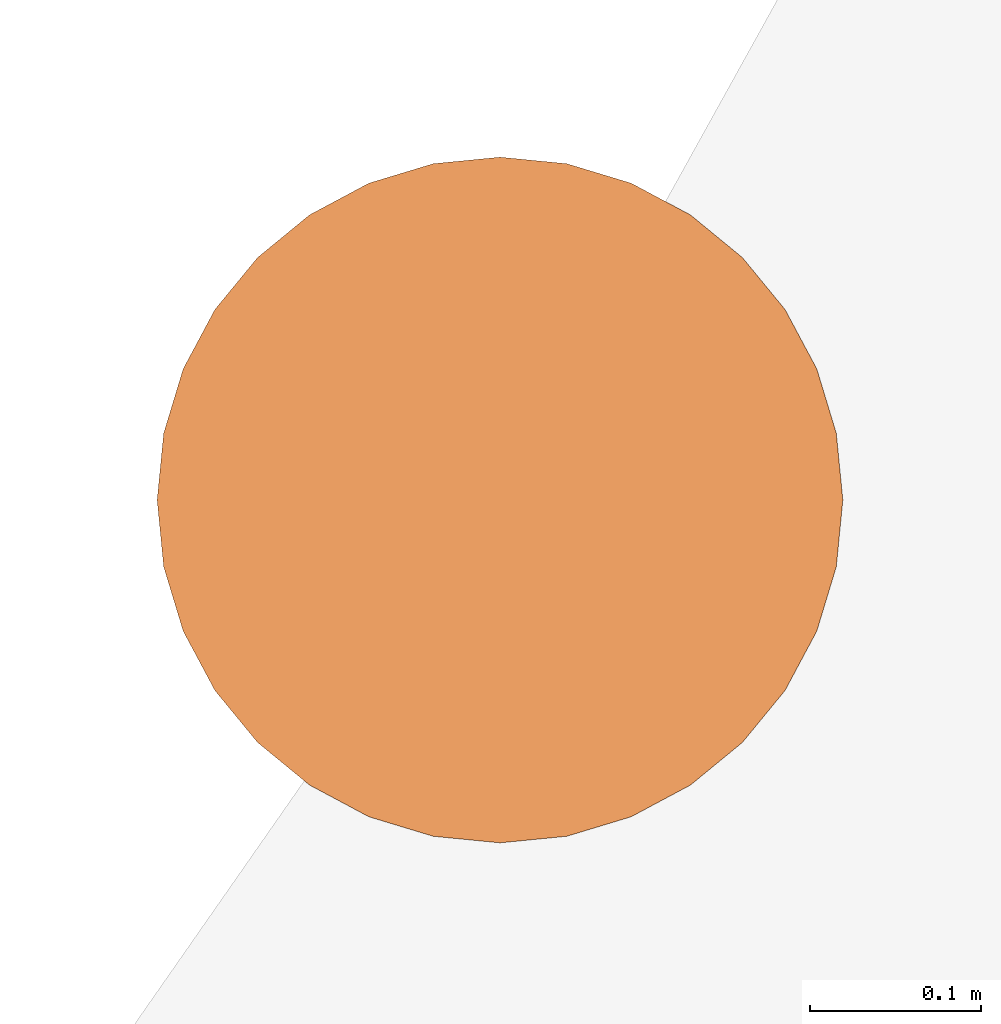
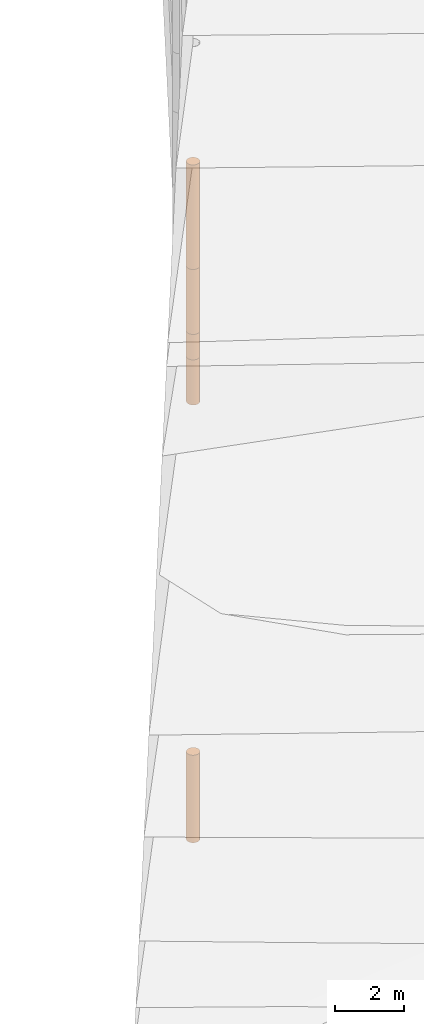
# One storey, part 9 of 24: 5 geographic elements.
"""IFC4 building model written with IfcOpenShell, lengths in metres."""

from ifc_helpers import new_model, entity, si_unit, converted_unit, frame, origin_with_axes, origin_2d_with_axis, place, context, subcontext, project, spatial, polygons, element, save


model = new_model("IFC4")

# Units and contexts
model_context = context("Model", 3, precision=1e-05, world=origin_with_axes())
plan_context = context("Plan", 2, precision=1e-05, world=origin_2d_with_axis())
body_context = subcontext(model_context, "Body", "Model", "MODEL_VIEW")
ifc_project = project(units=[converted_unit("PLANEANGLEUNIT", "degree", entity("IfcReal", 0.0174532925199433), si_unit("PLANEANGLEUNIT", "RADIAN"), dimensions=[0, 0, 0, 0, 0, 0, 0]), si_unit("AREAUNIT", "SQUARE_METRE"), si_unit("VOLUMEUNIT", "CUBIC_METRE"), si_unit("LENGTHUNIT", "METRE")], contexts=[model_context, plan_context])

# Site, building, storey
site_placement = place(None, origin_with_axes())
site = spatial("IfcSite", under=ifc_project, at=site_placement)
building_placement = place(site_placement, origin_with_axes())
building = spatial("IfcBuilding", under=site, at=building_placement, Name="Building")
storey_placement = place(building_placement, origin_with_axes())
storey = spatial("IfcBuildingStorey", under=building, at=storey_placement, Name="Storey")

# Geographic elements
geographic_element_1_placement = place(storey_placement, frame((-10.8999996185303, 35.5, 5.54999971389771), z_axis=(0.0, 0.0, 1.0), x_axis=(1.0, 0.0, 0.0)))
element("IfcGeographicElement", 1, at=geographic_element_1_placement, inside=storey, PredefinedType="NOTDEFINED", context=body_context, shape_type="Tessellation", body=[
    polygons([(0.0, 0.0, -0.449999958276749), (0.0390180610120296, 0.196157038211823, -0.449999958276749), (0.0, 0.199999988079071, -0.449999958276749), (0.0, 0.0, 0.449999958276749), (0.0, 0.199999988079071, 0.449999958276749), (0.0390180610120296, 0.196157038211823, 0.449999958276749), (0.0765366926789284, 0.18477588891983, -0.449999958276749), (0.0765366926789284, 0.18477588891983, 0.449999958276749), (0.111114047467709, 0.166293919086456, -0.449999958276749), (0.111114047467709, 0.166293919086456, 0.449999958276749), (0.141421362757683, 0.141421362757683, -0.449999958276749), (0.141421362757683, 0.141421362757683, 0.449999958276749), (0.166293919086456, 0.111114047467709, -0.449999958276749), (0.166293919086456, 0.111114047467709, 0.449999958276749), (0.18477588891983, 0.0765366926789284, -0.449999958276749), (0.18477588891983, 0.0765366926789284, 0.449999958276749), (0.196157038211823, 0.0390180610120296, -0.449999958276749), (0.196157038211823, 0.0390180610120296, 0.449999958276749), (0.199999988079071, 0.0, -0.449999958276749), (0.199999988079071, 0.0, 0.449999958276749), (0.196157038211823, -0.0390180610120296, -0.449999958276749), (0.196157038211823, -0.0390180610120296, 0.449999958276749), (0.18477588891983, -0.0765366926789284, -0.449999958276749), (0.18477588891983, -0.0765366926789284, 0.449999958276749), (0.166293919086456, -0.111114047467709, -0.449999958276749), (0.166293919086456, -0.111114047467709, 0.449999958276749), (0.141421362757683, -0.141421362757683, -0.449999958276749), (0.141421362757683, -0.141421362757683, 0.449999958276749), (0.111114047467709, -0.166293919086456, -0.449999958276749), (0.111114047467709, -0.166293919086456, 0.449999958276749), (0.0765366926789284, -0.18477588891983, -0.449999958276749), (0.0765366926789284, -0.18477588891983, 0.449999958276749), (0.0390180610120296, -0.196157038211823, -0.449999958276749), (0.0390180610120296, -0.196157038211823, 0.449999958276749), (0.0, -0.199999988079071, -0.449999958276749), (0.0, -0.199999988079071, 0.449999958276749), (-0.0390180610120296, -0.196157038211823, -0.449999958276749), (-0.0390180610120296, -0.196157038211823, 0.449999958276749), (-0.0765366926789284, -0.18477588891983, -0.449999958276749), (-0.0765366926789284, -0.18477588891983, 0.449999958276749), (-0.111114047467709, -0.166293919086456, -0.449999958276749), (-0.111114047467709, -0.166293919086456, 0.449999958276749), (-0.141421362757683, -0.141421362757683, -0.449999958276749), (-0.141421362757683, -0.141421362757683, 0.449999958276749), (-0.166293919086456, -0.111114047467709, -0.449999958276749), (-0.166293919086456, -0.111114047467709, 0.449999958276749), (-0.18477588891983, -0.0765366926789284, -0.449999958276749), (-0.18477588891983, -0.0765366926789284, 0.449999958276749), (-0.196157038211823, -0.0390180610120296, -0.449999958276749), (-0.196157038211823, -0.0390180610120296, 0.449999958276749), (-0.199999988079071, 0.0, -0.449999958276749), (-0.199999988079071, 0.0, 0.449999958276749), (-0.196157038211823, 0.0390180610120296, -0.449999958276749), (-0.196157038211823, 0.0390180610120296, 0.449999958276749), (-0.18477588891983, 0.0765366926789284, -0.449999958276749), (-0.18477588891983, 0.0765366926789284, 0.449999958276749), (-0.166293919086456, 0.111114047467709, -0.449999958276749), (-0.166293919086456, 0.111114047467709, 0.449999958276749), (-0.141421362757683, 0.141421362757683, -0.449999958276749), (-0.141421362757683, 0.141421362757683, 0.449999958276749), (-0.111114047467709, 0.166293919086456, -0.449999958276749), (-0.111114047467709, 0.166293919086456, 0.449999958276749), (-0.0765366926789284, 0.18477588891983, -0.449999958276749), (-0.0765366926789284, 0.18477588891983, 0.449999958276749), (-0.0390180610120296, 0.196157038211823, -0.449999958276749), (-0.0390180610120296, 0.196157038211823, 0.449999958276749)], [[[3, 2, 1]], [[6, 5, 4]], [[32, 34, 33, 31]], [[2, 7, 1]], [[8, 6, 4]], [[64, 66, 65, 63]], [[7, 9, 1]], [[10, 8, 4]], [[9, 11, 1]], [[12, 10, 4]], [[40, 42, 41, 39]], [[1, 11, 13]], [[12, 4, 14]], [[10, 12, 11, 9]], [[1, 13, 15]], [[4, 16, 14]], [[12, 14, 13, 11]], [[1, 15, 17]], [[16, 4, 18]], [[18, 20, 19, 17]], [[1, 17, 19]], [[4, 20, 18]], [[20, 22, 21, 19]], [[1, 19, 21]], [[4, 22, 20]], [[22, 24, 23, 21]], [[1, 21, 23]], [[22, 4, 24]], [[54, 56, 55, 53]], [[1, 23, 25]], [[4, 26, 24]], [[56, 58, 57, 55]], [[1, 25, 27]], [[4, 28, 26]], [[24, 26, 25, 23]], [[1, 27, 29]], [[28, 4, 30]], [[26, 28, 27, 25]], [[1, 29, 31]], [[4, 32, 30]], [[46, 48, 47, 45]], [[1, 31, 33]], [[4, 34, 32]], [[36, 38, 37, 35]], [[1, 33, 35]], [[4, 36, 34]], [[42, 44, 43, 41]], [[1, 35, 37]], [[4, 38, 36]], [[38, 40, 39, 37]], [[1, 37, 39]], [[4, 40, 38]], [[34, 36, 35, 33]], [[1, 39, 41]], [[4, 42, 40]], [[8, 10, 9, 7]], [[43, 1, 41]], [[4, 44, 42]], [[44, 46, 45, 43]], [[43, 45, 1]], [[4, 46, 44]], [[30, 32, 31, 29]], [[45, 47, 1]], [[48, 46, 4]], [[28, 30, 29, 27]], [[49, 1, 47]], [[4, 50, 48]], [[5, 6, 2, 3]], [[49, 51, 1]], [[52, 50, 4]], [[48, 50, 49, 47]], [[51, 53, 1]], [[54, 52, 4]], [[50, 52, 51, 49]], [[55, 1, 53]], [[4, 56, 54]], [[52, 54, 53, 51]], [[55, 57, 1]], [[58, 56, 4]], [[58, 60, 59, 57]], [[59, 1, 57]], [[60, 58, 4]], [[60, 62, 61, 59]], [[59, 61, 1]], [[62, 60, 4]], [[62, 64, 63, 61]], [[61, 63, 1]], [[64, 62, 4]], [[14, 16, 15, 13]], [[63, 65, 1]], [[66, 64, 4]], [[16, 18, 17, 15]], [[65, 3, 1]], [[5, 66, 4]], [[6, 8, 7, 2]], [[66, 5, 3, 65]]]),
])
geographic_element_2_placement = place(storey_placement, frame((-10.8999996185303, 35.5, 10.1499996185303), z_axis=(0.0, 0.0, 1.0), x_axis=(1.0, 0.0, 0.0)))
element("IfcGeographicElement", 2, at=geographic_element_2_placement, inside=storey, PredefinedType="NOTDEFINED", context=body_context, shape_type="Tessellation", body=[
    polygons([(0.0, 0.0, -1.84999990463257), (0.0390180610120296, 0.196157038211823, -1.84999990463257), (0.0, 0.199999988079071, -1.84999990463257), (0.0, 0.0, 1.84999990463257), (0.0, 0.199999988079071, 1.84999990463257), (0.0390180610120296, 0.196157038211823, 1.84999990463257), (0.0765366926789284, 0.18477588891983, -1.84999990463257), (0.0765366926789284, 0.18477588891983, 1.84999990463257), (0.111114047467709, 0.166293919086456, -1.84999990463257), (0.111114047467709, 0.166293919086456, 1.84999990463257), (0.141421362757683, 0.141421362757683, -1.84999990463257), (0.141421362757683, 0.141421362757683, 1.84999990463257), (0.166293919086456, 0.111114047467709, -1.84999990463257), (0.166293919086456, 0.111114047467709, 1.84999990463257), (0.18477588891983, 0.0765366926789284, -1.84999990463257), (0.18477588891983, 0.0765366926789284, 1.84999990463257), (0.196157038211823, 0.0390180610120296, -1.84999990463257), (0.196157038211823, 0.0390180610120296, 1.84999990463257), (0.199999988079071, 0.0, -1.84999990463257), (0.199999988079071, 0.0, 1.84999990463257), (0.196157038211823, -0.0390180610120296, -1.84999990463257), (0.196157038211823, -0.0390180610120296, 1.84999990463257), (0.18477588891983, -0.0765366926789284, -1.84999990463257), (0.18477588891983, -0.0765366926789284, 1.84999990463257), (0.166293919086456, -0.111114047467709, -1.84999990463257), (0.166293919086456, -0.111114047467709, 1.84999990463257), (0.141421362757683, -0.141421362757683, -1.84999990463257), (0.141421362757683, -0.141421362757683, 1.84999990463257), (0.111114047467709, -0.166293919086456, -1.84999990463257), (0.111114047467709, -0.166293919086456, 1.84999990463257), (0.0765366926789284, -0.18477588891983, -1.84999990463257), (0.0765366926789284, -0.18477588891983, 1.84999990463257), (0.0390180610120296, -0.196157038211823, -1.84999990463257), (0.0390180610120296, -0.196157038211823, 1.84999990463257), (0.0, -0.199999988079071, -1.84999990463257), (0.0, -0.199999988079071, 1.84999990463257), (-0.0390180610120296, -0.196157038211823, -1.84999990463257), (-0.0390180610120296, -0.196157038211823, 1.84999990463257), (-0.0765366926789284, -0.18477588891983, -1.84999990463257), (-0.0765366926789284, -0.18477588891983, 1.84999990463257), (-0.111114047467709, -0.166293919086456, -1.84999990463257), (-0.111114047467709, -0.166293919086456, 1.84999990463257), (-0.141421362757683, -0.141421362757683, -1.84999990463257), (-0.141421362757683, -0.141421362757683, 1.84999990463257), (-0.166293919086456, -0.111114047467709, -1.84999990463257), (-0.166293919086456, -0.111114047467709, 1.84999990463257), (-0.18477588891983, -0.0765366926789284, -1.84999990463257), (-0.18477588891983, -0.0765366926789284, 1.84999990463257), (-0.196157038211823, -0.0390180610120296, -1.84999990463257), (-0.196157038211823, -0.0390180610120296, 1.84999990463257), (-0.199999988079071, 0.0, -1.84999990463257), (-0.199999988079071, 0.0, 1.84999990463257), (-0.196157038211823, 0.0390180610120296, -1.84999990463257), (-0.196157038211823, 0.0390180610120296, 1.84999990463257), (-0.18477588891983, 0.0765366926789284, -1.84999990463257), (-0.18477588891983, 0.0765366926789284, 1.84999990463257), (-0.166293919086456, 0.111114047467709, -1.84999990463257), (-0.166293919086456, 0.111114047467709, 1.84999990463257), (-0.141421362757683, 0.141421362757683, -1.84999990463257), (-0.141421362757683, 0.141421362757683, 1.84999990463257), (-0.111114047467709, 0.166293919086456, -1.84999990463257), (-0.111114047467709, 0.166293919086456, 1.84999990463257), (-0.0765366926789284, 0.18477588891983, -1.84999990463257), (-0.0765366926789284, 0.18477588891983, 1.84999990463257), (-0.0390180610120296, 0.196157038211823, -1.84999990463257), (-0.0390180610120296, 0.196157038211823, 1.84999990463257)], [[[3, 2, 1]], [[6, 5, 4]], [[62, 64, 63, 61]], [[2, 7, 1]], [[8, 6, 4]], [[30, 32, 31, 29]], [[7, 9, 1]], [[10, 8, 4]], [[10, 12, 11, 9]], [[9, 11, 1]], [[12, 10, 4]], [[11, 13, 1]], [[12, 4, 14]], [[66, 5, 3, 65]], [[1, 13, 15]], [[4, 16, 14]], [[42, 44, 43, 41]], [[1, 15, 17]], [[4, 18, 16]], [[48, 50, 49, 47]], [[1, 17, 19]], [[4, 20, 18]], [[16, 18, 17, 15]], [[1, 19, 21]], [[4, 22, 20]], [[50, 52, 51, 49]], [[1, 21, 23]], [[22, 4, 24]], [[54, 56, 55, 53]], [[1, 23, 25]], [[24, 4, 26]], [[56, 58, 57, 55]], [[27, 1, 25]], [[26, 4, 28]], [[58, 60, 59, 57]], [[1, 27, 29]], [[28, 4, 30]], [[60, 62, 61, 59]], [[1, 29, 31]], [[4, 32, 30]], [[64, 66, 65, 63]], [[1, 31, 33]], [[4, 34, 32]], [[6, 8, 7, 2]], [[1, 33, 35]], [[4, 36, 34]], [[8, 10, 9, 7]], [[1, 35, 37]], [[4, 38, 36]], [[32, 34, 33, 31]], [[1, 37, 39]], [[4, 40, 38]], [[36, 38, 37, 35]], [[1, 39, 41]], [[4, 42, 40]], [[46, 48, 47, 45]], [[43, 1, 41]], [[4, 44, 42]], [[34, 36, 35, 33]], [[45, 1, 43]], [[46, 44, 4]], [[14, 16, 15, 13]], [[47, 1, 45]], [[48, 46, 4]], [[44, 46, 45, 43]], [[49, 1, 47]], [[50, 48, 4]], [[40, 42, 41, 39]], [[49, 51, 1]], [[52, 50, 4]], [[18, 20, 19, 17]], [[51, 53, 1]], [[54, 52, 4]], [[20, 22, 21, 19]], [[53, 55, 1]], [[4, 56, 54]], [[52, 54, 53, 51]], [[55, 57, 1]], [[4, 58, 56]], [[22, 24, 23, 21]], [[57, 59, 1]], [[60, 58, 4]], [[24, 26, 25, 23]], [[59, 61, 1]], [[62, 60, 4]], [[26, 28, 27, 25]], [[61, 63, 1]], [[64, 62, 4]], [[28, 30, 29, 27]], [[63, 65, 1]], [[66, 64, 4]], [[5, 6, 2, 3]], [[65, 3, 1]], [[5, 66, 4]], [[38, 40, 39, 37]], [[12, 14, 13, 11]]]),
])
geographic_element_3_placement = place(storey_placement, frame((-10.8999996185303, 35.5, 4.29999971389771), z_axis=(0.0, 0.0, 1.0), x_axis=(1.0, 0.0, 0.0)))
element("IfcGeographicElement", 3, at=geographic_element_3_placement, inside=storey, PredefinedType="NOTDEFINED", context=body_context, shape_type="Tessellation", body=[
    polygons([(0.0, 0.0, -0.799999952316284), (0.0390180610120296, 0.196157038211823, -0.799999952316284), (0.0, 0.199999988079071, -0.799999952316284), (0.0, 0.0, 0.799999952316284), (0.0, 0.199999988079071, 0.799999952316284), (0.0390180610120296, 0.196157038211823, 0.799999952316284), (0.0765366926789284, 0.18477588891983, -0.799999952316284), (0.0765366926789284, 0.18477588891983, 0.799999952316284), (0.111114047467709, 0.166293919086456, -0.799999952316284), (0.111114047467709, 0.166293919086456, 0.799999952316284), (0.141421362757683, 0.141421362757683, -0.799999952316284), (0.141421362757683, 0.141421362757683, 0.799999952316284), (0.166293919086456, 0.111114047467709, -0.799999952316284), (0.166293919086456, 0.111114047467709, 0.799999952316284), (0.18477588891983, 0.0765366926789284, -0.799999952316284), (0.18477588891983, 0.0765366926789284, 0.799999952316284), (0.196157038211823, 0.0390180610120296, -0.799999952316284), (0.196157038211823, 0.0390180610120296, 0.799999952316284), (0.199999988079071, 0.0, -0.799999952316284), (0.199999988079071, 0.0, 0.799999952316284), (0.196157038211823, -0.0390180610120296, -0.799999952316284), (0.196157038211823, -0.0390180610120296, 0.799999952316284), (0.18477588891983, -0.0765366926789284, -0.799999952316284), (0.18477588891983, -0.0765366926789284, 0.799999952316284), (0.166293919086456, -0.111114047467709, -0.799999952316284), (0.166293919086456, -0.111114047467709, 0.799999952316284), (0.141421362757683, -0.141421362757683, -0.799999952316284), (0.141421362757683, -0.141421362757683, 0.799999952316284), (0.111114047467709, -0.166293919086456, -0.799999952316284), (0.111114047467709, -0.166293919086456, 0.799999952316284), (0.0765366926789284, -0.18477588891983, -0.799999952316284), (0.0765366926789284, -0.18477588891983, 0.799999952316284), (0.0390180610120296, -0.196157038211823, -0.799999952316284), (0.0390180610120296, -0.196157038211823, 0.799999952316284), (0.0, -0.199999988079071, -0.799999952316284), (0.0, -0.199999988079071, 0.799999952316284), (-0.0390180610120296, -0.196157038211823, -0.799999952316284), (-0.0390180610120296, -0.196157038211823, 0.799999952316284), (-0.0765366926789284, -0.18477588891983, -0.799999952316284), (-0.0765366926789284, -0.18477588891983, 0.799999952316284), (-0.111114047467709, -0.166293919086456, -0.799999952316284), (-0.111114047467709, -0.166293919086456, 0.799999952316284), (-0.141421362757683, -0.141421362757683, -0.799999952316284), (-0.141421362757683, -0.141421362757683, 0.799999952316284), (-0.166293919086456, -0.111114047467709, -0.799999952316284), (-0.166293919086456, -0.111114047467709, 0.799999952316284), (-0.18477588891983, -0.0765366926789284, -0.799999952316284), (-0.18477588891983, -0.0765366926789284, 0.799999952316284), (-0.196157038211823, -0.0390180610120296, -0.799999952316284), (-0.196157038211823, -0.0390180610120296, 0.799999952316284), (-0.199999988079071, 0.0, -0.799999952316284), (-0.199999988079071, 0.0, 0.799999952316284), (-0.196157038211823, 0.0390180610120296, -0.799999952316284), (-0.196157038211823, 0.0390180610120296, 0.799999952316284), (-0.18477588891983, 0.0765366926789284, -0.799999952316284), (-0.18477588891983, 0.0765366926789284, 0.799999952316284), (-0.166293919086456, 0.111114047467709, -0.799999952316284), (-0.166293919086456, 0.111114047467709, 0.799999952316284), (-0.141421362757683, 0.141421362757683, -0.799999952316284), (-0.141421362757683, 0.141421362757683, 0.799999952316284), (-0.111114047467709, 0.166293919086456, -0.799999952316284), (-0.111114047467709, 0.166293919086456, 0.799999952316284), (-0.0765366926789284, 0.18477588891983, -0.799999952316284), (-0.0765366926789284, 0.18477588891983, 0.799999952316284), (-0.0390180610120296, 0.196157038211823, -0.799999952316284), (-0.0390180610120296, 0.196157038211823, 0.799999952316284)], [[[3, 2, 1]], [[6, 5, 4]], [[28, 30, 29, 27]], [[2, 7, 1]], [[8, 6, 4]], [[36, 38, 37, 35]], [[7, 9, 1]], [[10, 8, 4]], [[56, 58, 57, 55]], [[9, 11, 1]], [[12, 10, 4]], [[58, 60, 59, 57]], [[11, 13, 1]], [[12, 4, 14]], [[54, 56, 55, 53]], [[1, 13, 15]], [[14, 4, 16]], [[10, 12, 11, 9]], [[1, 15, 17]], [[4, 18, 16]], [[60, 62, 61, 59]], [[1, 17, 19]], [[4, 20, 18]], [[16, 18, 17, 15]], [[1, 19, 21]], [[4, 22, 20]], [[18, 20, 19, 17]], [[1, 21, 23]], [[4, 24, 22]], [[20, 22, 21, 19]], [[1, 23, 25]], [[24, 4, 26]], [[22, 24, 23, 21]], [[27, 1, 25]], [[26, 4, 28]], [[24, 26, 25, 23]], [[1, 27, 29]], [[28, 4, 30]], [[62, 64, 63, 61]], [[1, 29, 31]], [[4, 32, 30]], [[64, 66, 65, 63]], [[1, 31, 33]], [[4, 34, 32]], [[30, 32, 31, 29]], [[1, 33, 35]], [[4, 36, 34]], [[8, 10, 9, 7]], [[1, 35, 37]], [[4, 38, 36]], [[32, 34, 33, 31]], [[1, 37, 39]], [[4, 40, 38]], [[6, 8, 7, 2]], [[1, 39, 41]], [[4, 42, 40]], [[38, 40, 39, 37]], [[43, 1, 41]], [[4, 44, 42]], [[40, 42, 41, 39]], [[45, 1, 43]], [[46, 44, 4]], [[42, 44, 43, 41]], [[47, 1, 45]], [[4, 48, 46]], [[44, 46, 45, 43]], [[47, 49, 1]], [[50, 48, 4]], [[46, 48, 47, 45]], [[49, 51, 1]], [[52, 50, 4]], [[48, 50, 49, 47]], [[51, 53, 1]], [[54, 52, 4]], [[66, 5, 3, 65]], [[53, 55, 1]], [[56, 54, 4]], [[52, 54, 53, 51]], [[57, 1, 55]], [[4, 58, 56]], [[57, 59, 1]], [[60, 58, 4]], [[34, 36, 35, 33]], [[59, 61, 1]], [[62, 60, 4]], [[14, 16, 15, 13]], [[61, 63, 1]], [[64, 62, 4]], [[26, 28, 27, 25]], [[63, 65, 1]], [[66, 64, 4]], [[5, 6, 2, 3]], [[65, 3, 1]], [[5, 66, 4]], [[50, 52, 51, 49]], [[12, 14, 13, 11]]]),
])
geographic_element_4_placement = place(storey_placement, frame((-10.8999996185303, 35.5, 7.14999961853027), z_axis=(0.0, 0.0, 1.0), x_axis=(1.0, 0.0, 0.0)))
element("IfcGeographicElement", 4, at=geographic_element_4_placement, inside=storey, PredefinedType="NOTDEFINED", context=body_context, shape_type="Tessellation", body=[
    polygons([(0.0, 0.0, -1.14999985694885), (0.0390180610120296, 0.196157038211823, -1.14999985694885), (0.0, 0.199999988079071, -1.14999985694885), (0.0, 0.0, 1.14999985694885), (0.0, 0.199999988079071, 1.14999985694885), (0.0390180610120296, 0.196157038211823, 1.14999985694885), (0.0765366926789284, 0.18477588891983, -1.14999985694885), (0.0765366926789284, 0.18477588891983, 1.14999985694885), (0.111114047467709, 0.166293919086456, -1.14999985694885), (0.111114047467709, 0.166293919086456, 1.14999985694885), (0.141421362757683, 0.141421362757683, -1.14999985694885), (0.141421362757683, 0.141421362757683, 1.14999985694885), (0.166293919086456, 0.111114047467709, -1.14999985694885), (0.166293919086456, 0.111114047467709, 1.14999985694885), (0.18477588891983, 0.0765366926789284, -1.14999985694885), (0.18477588891983, 0.0765366926789284, 1.14999985694885), (0.196157038211823, 0.0390180610120296, -1.14999985694885), (0.196157038211823, 0.0390180610120296, 1.14999985694885), (0.199999988079071, 0.0, -1.14999985694885), (0.199999988079071, 0.0, 1.14999985694885), (0.196157038211823, -0.0390180610120296, -1.14999985694885), (0.196157038211823, -0.0390180610120296, 1.14999985694885), (0.18477588891983, -0.0765366926789284, -1.14999985694885), (0.18477588891983, -0.0765366926789284, 1.14999985694885), (0.166293919086456, -0.111114047467709, -1.14999985694885), (0.166293919086456, -0.111114047467709, 1.14999985694885), (0.141421362757683, -0.141421362757683, -1.14999985694885), (0.141421362757683, -0.141421362757683, 1.14999985694885), (0.111114047467709, -0.166293919086456, -1.14999985694885), (0.111114047467709, -0.166293919086456, 1.14999985694885), (0.0765366926789284, -0.18477588891983, -1.14999985694885), (0.0765366926789284, -0.18477588891983, 1.14999985694885), (0.0390180610120296, -0.196157038211823, -1.14999985694885), (0.0390180610120296, -0.196157038211823, 1.14999985694885), (0.0, -0.199999988079071, -1.14999985694885), (0.0, -0.199999988079071, 1.14999985694885), (-0.0390180610120296, -0.196157038211823, -1.14999985694885), (-0.0390180610120296, -0.196157038211823, 1.14999985694885), (-0.0765366926789284, -0.18477588891983, -1.14999985694885), (-0.0765366926789284, -0.18477588891983, 1.14999985694885), (-0.111114047467709, -0.166293919086456, -1.14999985694885), (-0.111114047467709, -0.166293919086456, 1.14999985694885), (-0.141421362757683, -0.141421362757683, -1.14999985694885), (-0.141421362757683, -0.141421362757683, 1.14999985694885), (-0.166293919086456, -0.111114047467709, -1.14999985694885), (-0.166293919086456, -0.111114047467709, 1.14999985694885), (-0.18477588891983, -0.0765366926789284, -1.14999985694885), (-0.18477588891983, -0.0765366926789284, 1.14999985694885), (-0.196157038211823, -0.0390180610120296, -1.14999985694885), (-0.196157038211823, -0.0390180610120296, 1.14999985694885), (-0.199999988079071, 0.0, -1.14999985694885), (-0.199999988079071, 0.0, 1.14999985694885), (-0.196157038211823, 0.0390180610120296, -1.14999985694885), (-0.196157038211823, 0.0390180610120296, 1.14999985694885), (-0.18477588891983, 0.0765366926789284, -1.14999985694885), (-0.18477588891983, 0.0765366926789284, 1.14999985694885), (-0.166293919086456, 0.111114047467709, -1.14999985694885), (-0.166293919086456, 0.111114047467709, 1.14999985694885), (-0.141421362757683, 0.141421362757683, -1.14999985694885), (-0.141421362757683, 0.141421362757683, 1.14999985694885), (-0.111114047467709, 0.166293919086456, -1.14999985694885), (-0.111114047467709, 0.166293919086456, 1.14999985694885), (-0.0765366926789284, 0.18477588891983, -1.14999985694885), (-0.0765366926789284, 0.18477588891983, 1.14999985694885), (-0.0390180610120296, 0.196157038211823, -1.14999985694885), (-0.0390180610120296, 0.196157038211823, 1.14999985694885)], [[[3, 2, 1]], [[6, 5, 4]], [[28, 30, 29, 27]], [[2, 7, 1]], [[8, 6, 4]], [[64, 66, 65, 63]], [[7, 9, 1]], [[10, 8, 4]], [[9, 11, 1]], [[12, 10, 4]], [[6, 8, 7, 2]], [[1, 11, 13]], [[12, 4, 14]], [[66, 5, 3, 65]], [[1, 13, 15]], [[4, 16, 14]], [[12, 14, 13, 11]], [[1, 15, 17]], [[16, 4, 18]], [[14, 16, 15, 13]], [[1, 17, 19]], [[18, 4, 20]], [[16, 18, 17, 15]], [[1, 19, 21]], [[20, 4, 22]], [[18, 20, 19, 17]], [[1, 21, 23]], [[22, 4, 24]], [[20, 22, 21, 19]], [[1, 23, 25]], [[4, 26, 24]], [[22, 24, 23, 21]], [[27, 1, 25]], [[4, 28, 26]], [[24, 26, 25, 23]], [[1, 27, 29]], [[28, 4, 30]], [[26, 28, 27, 25]], [[1, 29, 31]], [[4, 32, 30]], [[5, 6, 2, 3]], [[1, 31, 33]], [[4, 34, 32]], [[30, 32, 31, 29]], [[1, 33, 35]], [[4, 36, 34]], [[8, 10, 9, 7]], [[1, 35, 37]], [[4, 38, 36]], [[32, 34, 33, 31]], [[1, 37, 39]], [[4, 40, 38]], [[36, 38, 37, 35]], [[1, 39, 41]], [[4, 42, 40]], [[38, 40, 39, 37]], [[43, 1, 41]], [[4, 44, 42]], [[40, 42, 41, 39]], [[43, 45, 1]], [[46, 44, 4]], [[42, 44, 43, 41]], [[45, 47, 1]], [[48, 46, 4]], [[44, 46, 45, 43]], [[49, 1, 47]], [[4, 50, 48]], [[46, 48, 47, 45]], [[51, 1, 49]], [[4, 52, 50]], [[48, 50, 49, 47]], [[53, 1, 51]], [[4, 54, 52]], [[50, 52, 51, 49]], [[55, 1, 53]], [[4, 56, 54]], [[52, 54, 53, 51]], [[55, 57, 1]], [[58, 56, 4]], [[54, 56, 55, 53]], [[57, 59, 1]], [[60, 58, 4]], [[56, 58, 57, 55]], [[59, 61, 1]], [[62, 60, 4]], [[58, 60, 59, 57]], [[61, 63, 1]], [[64, 62, 4]], [[60, 62, 61, 59]], [[63, 65, 1]], [[66, 64, 4]], [[62, 64, 63, 61]], [[65, 3, 1]], [[5, 66, 4]], [[34, 36, 35, 33]], [[10, 12, 11, 9]]]),
])
geographic_element_5_placement = place(storey_placement, frame((-10.8999996185303, 35.5, -10.4500007629395), z_axis=(0.0, 0.0, 1.0), x_axis=(1.0, 0.0, 0.0)))
element("IfcGeographicElement", 5, at=geographic_element_5_placement, inside=storey, PredefinedType="NOTDEFINED", context=body_context, shape_type="Tessellation", body=[
    polygons([(0.0, 0.0, -1.54999983310699), (0.0390180610120296, 0.196157038211823, -1.54999983310699), (0.0, 0.199999988079071, -1.54999983310699), (0.0, 0.0, 1.54999983310699), (0.0, 0.199999988079071, 1.54999983310699), (0.0390180610120296, 0.196157038211823, 1.54999983310699), (0.0765366926789284, 0.18477588891983, -1.54999983310699), (0.0765366926789284, 0.18477588891983, 1.54999983310699), (0.111114047467709, 0.166293919086456, -1.54999983310699), (0.111114047467709, 0.166293919086456, 1.54999983310699), (0.141421362757683, 0.141421362757683, -1.54999983310699), (0.141421362757683, 0.141421362757683, 1.54999983310699), (0.166293919086456, 0.111114047467709, -1.54999983310699), (0.166293919086456, 0.111114047467709, 1.54999983310699), (0.18477588891983, 0.0765366926789284, -1.54999983310699), (0.18477588891983, 0.0765366926789284, 1.54999983310699), (0.196157038211823, 0.0390180610120296, -1.54999983310699), (0.196157038211823, 0.0390180610120296, 1.54999983310699), (0.199999988079071, 0.0, -1.54999983310699), (0.199999988079071, 0.0, 1.54999983310699), (0.196157038211823, -0.0390180610120296, -1.54999983310699), (0.196157038211823, -0.0390180610120296, 1.54999983310699), (0.18477588891983, -0.0765366926789284, -1.54999983310699), (0.18477588891983, -0.0765366926789284, 1.54999983310699), (0.166293919086456, -0.111114047467709, -1.54999983310699), (0.166293919086456, -0.111114047467709, 1.54999983310699), (0.141421362757683, -0.141421362757683, -1.54999983310699), (0.141421362757683, -0.141421362757683, 1.54999983310699), (0.111114047467709, -0.166293919086456, -1.54999983310699), (0.111114047467709, -0.166293919086456, 1.54999983310699), (0.0765366926789284, -0.18477588891983, -1.54999983310699), (0.0765366926789284, -0.18477588891983, 1.54999983310699), (0.0390180610120296, -0.196157038211823, -1.54999983310699), (0.0390180610120296, -0.196157038211823, 1.54999983310699), (0.0, -0.199999988079071, -1.54999983310699), (0.0, -0.199999988079071, 1.54999983310699), (-0.0390180610120296, -0.196157038211823, -1.54999983310699), (-0.0390180610120296, -0.196157038211823, 1.54999983310699), (-0.0765366926789284, -0.18477588891983, -1.54999983310699), (-0.0765366926789284, -0.18477588891983, 1.54999983310699), (-0.111114047467709, -0.166293919086456, -1.54999983310699), (-0.111114047467709, -0.166293919086456, 1.54999983310699), (-0.141421362757683, -0.141421362757683, -1.54999983310699), (-0.141421362757683, -0.141421362757683, 1.54999983310699), (-0.166293919086456, -0.111114047467709, -1.54999983310699), (-0.166293919086456, -0.111114047467709, 1.54999983310699), (-0.18477588891983, -0.0765366926789284, -1.54999983310699), (-0.18477588891983, -0.0765366926789284, 1.54999983310699), (-0.196157038211823, -0.0390180610120296, -1.54999983310699), (-0.196157038211823, -0.0390180610120296, 1.54999983310699), (-0.199999988079071, 0.0, -1.54999983310699), (-0.199999988079071, 0.0, 1.54999983310699), (-0.196157038211823, 0.0390180610120296, -1.54999983310699), (-0.196157038211823, 0.0390180610120296, 1.54999983310699), (-0.18477588891983, 0.0765366926789284, -1.54999983310699), (-0.18477588891983, 0.0765366926789284, 1.54999983310699), (-0.166293919086456, 0.111114047467709, -1.54999983310699), (-0.166293919086456, 0.111114047467709, 1.54999983310699), (-0.141421362757683, 0.141421362757683, -1.54999983310699), (-0.141421362757683, 0.141421362757683, 1.54999983310699), (-0.111114047467709, 0.166293919086456, -1.54999983310699), (-0.111114047467709, 0.166293919086456, 1.54999983310699), (-0.0765366926789284, 0.18477588891983, -1.54999983310699), (-0.0765366926789284, 0.18477588891983, 1.54999983310699), (-0.0390180610120296, 0.196157038211823, -1.54999983310699), (-0.0390180610120296, 0.196157038211823, 1.54999983310699)], [[[3, 2, 1]], [[6, 5, 4]], [[32, 34, 33, 31]], [[2, 7, 1]], [[8, 6, 4]], [[64, 66, 65, 63]], [[7, 9, 1]], [[10, 8, 4]], [[9, 11, 1]], [[12, 10, 4]], [[40, 42, 41, 39]], [[1, 11, 13]], [[12, 4, 14]], [[10, 12, 11, 9]], [[1, 13, 15]], [[14, 4, 16]], [[12, 14, 13, 11]], [[1, 15, 17]], [[4, 18, 16]], [[18, 20, 19, 17]], [[1, 17, 19]], [[4, 20, 18]], [[20, 22, 21, 19]], [[1, 19, 21]], [[4, 22, 20]], [[22, 24, 23, 21]], [[1, 21, 23]], [[4, 24, 22]], [[54, 56, 55, 53]], [[1, 23, 25]], [[24, 4, 26]], [[56, 58, 57, 55]], [[1, 25, 27]], [[4, 28, 26]], [[24, 26, 25, 23]], [[1, 27, 29]], [[28, 4, 30]], [[26, 28, 27, 25]], [[1, 29, 31]], [[4, 32, 30]], [[46, 48, 47, 45]], [[1, 31, 33]], [[4, 34, 32]], [[36, 38, 37, 35]], [[1, 33, 35]], [[4, 36, 34]], [[42, 44, 43, 41]], [[1, 35, 37]], [[4, 38, 36]], [[38, 40, 39, 37]], [[1, 37, 39]], [[4, 40, 38]], [[34, 36, 35, 33]], [[1, 39, 41]], [[4, 42, 40]], [[8, 10, 9, 7]], [[43, 1, 41]], [[4, 44, 42]], [[44, 46, 45, 43]], [[43, 45, 1]], [[4, 46, 44]], [[30, 32, 31, 29]], [[47, 1, 45]], [[4, 48, 46]], [[28, 30, 29, 27]], [[47, 49, 1]], [[50, 48, 4]], [[5, 6, 2, 3]], [[49, 51, 1]], [[52, 50, 4]], [[48, 50, 49, 47]], [[51, 53, 1]], [[54, 52, 4]], [[50, 52, 51, 49]], [[53, 55, 1]], [[56, 54, 4]], [[52, 54, 53, 51]], [[57, 1, 55]], [[4, 58, 56]], [[58, 60, 59, 57]], [[59, 1, 57]], [[60, 58, 4]], [[60, 62, 61, 59]], [[59, 61, 1]], [[62, 60, 4]], [[62, 64, 63, 61]], [[61, 63, 1]], [[64, 62, 4]], [[14, 16, 15, 13]], [[63, 65, 1]], [[66, 64, 4]], [[16, 18, 17, 15]], [[65, 3, 1]], [[5, 66, 4]], [[6, 8, 7, 2]], [[66, 5, 3, 65]]]),
])

save(model, "model.ifc")
